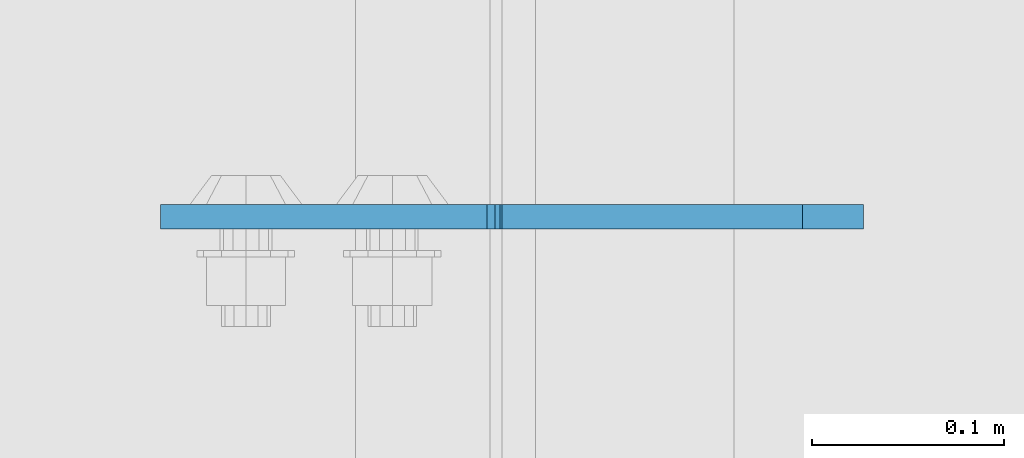
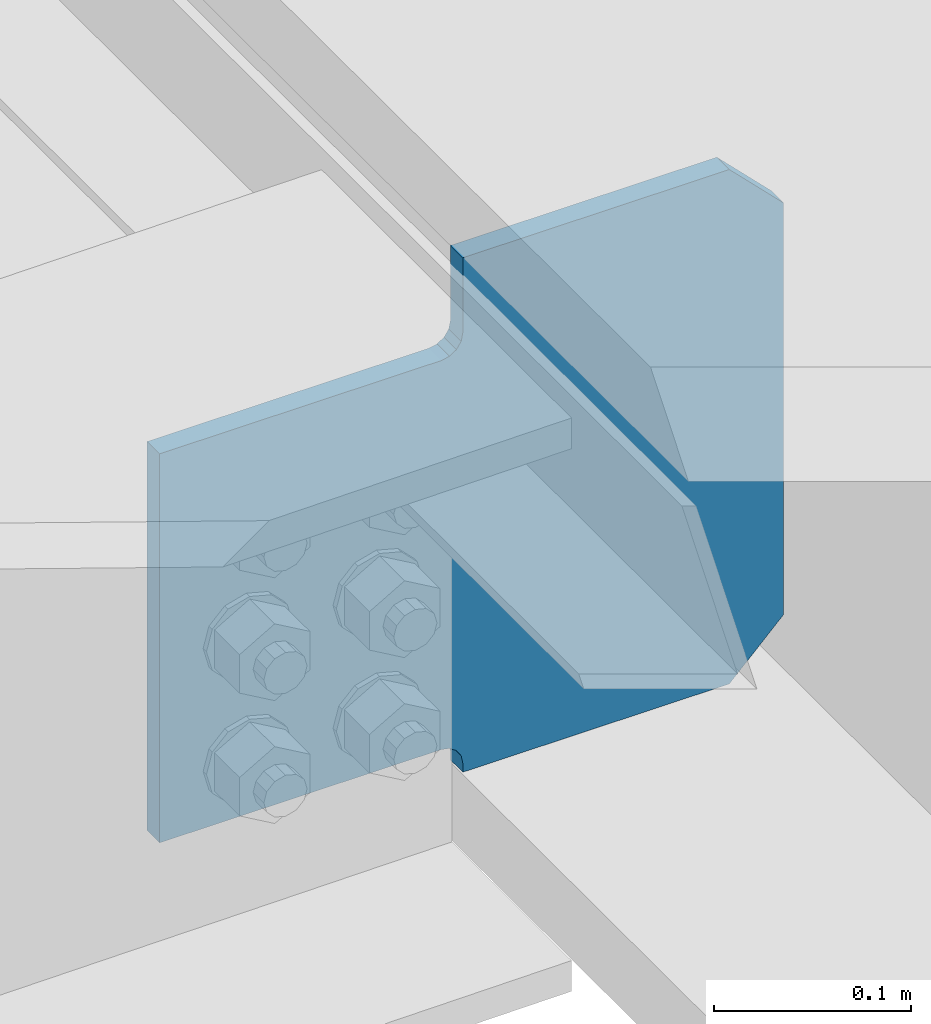
# One storey, part 3611 of 3843: 1 plate, 1 element without a shape of its own.
"""IFC2X3 building model written with IfcOpenShell, lengths in millimetres."""

from ifc_helpers import new_model, si_unit, frame, origin_with_axes, place, context, subcontext, project, spatial, faceted_brep, material, type_object, element, aggregate, save


model = new_model("IFC2X3")

# Units and contexts
model_context = context("Model", 3, precision=1e-05, world=origin_with_axes())
body_context = subcontext(model_context, "Body", "Model", "MODEL_VIEW")
ifc_project = project(units=[si_unit("LENGTHUNIT", "METRE", prefix="MILLI"), si_unit("AREAUNIT", "SQUARE_METRE"), si_unit("VOLUMEUNIT", "CUBIC_METRE"), si_unit("MASSUNIT", "GRAM", prefix="KILO"), si_unit("TIMEUNIT", "SECOND"), si_unit("PLANEANGLEUNIT", "RADIAN"), si_unit("SOLIDANGLEUNIT", "STERADIAN"), si_unit("THERMODYNAMICTEMPERATUREUNIT", "DEGREE_CELSIUS"), si_unit("LUMINOUSINTENSITYUNIT", "LUMEN")], contexts=[model_context])

# Site, building, storey
site_placement = place(None, origin_with_axes())
site = spatial("IfcSite", under=ifc_project, at=site_placement, CompositionType="ELEMENT")
building_placement = place(site_placement, origin_with_axes())
building = spatial("IfcBuilding", under=site, at=building_placement, Name="Undefined", CompositionType="ELEMENT")
storey_placement = place(building_placement, origin_with_axes())
storey = spatial("IfcBuildingStorey", under=building, at=storey_placement, Name="Undefined", CompositionType="ELEMENT", Elevation=0.0)

# Assembly, plate
assembly_placement = place(storey_placement, origin_with_axes())
assembly = element("IfcElementAssembly", 1, at=assembly_placement, inside=storey, Name="BEAM", AssemblyPlace="NOTDEFINED", PredefinedType="RIGID_FRAME")
ifc_material = material(Name="STEEL/A572-50")
plate_type = type_object("IfcPlateType", PredefinedType="NOTDEFINED")
plate_placement = place(assembly_placement, frame((85633.7187497331, 64497.545318173, 39422.8776364042), z_axis=(-0.707106781186548, 0.0, 0.707106781186548), x_axis=(-0.707106781186548, 0.0, -0.707106781186548)))
plate = element("IfcPlate", 2, at=plate_placement, type_object=plate_type, material=ifc_material, Name="PLATE", context=body_context, shape_type="Brep", body=[
    faceted_brep([(0.0, -6.3499999046162, 0.0), (-180.719415212428, -6.34999999999854, 180.719415212476), (-180.719415212428, 6.34999999999854, 180.719415212476), (7.27595761418343e-12, 6.3499999046162, 0.0), (-180.719415211977, -6.34999999999854, 225.620695818059), (-180.719415211977, 6.34999999999854, 225.620695818059), (-70.1500118726253, -6.34999999999854, 336.190099157397), (-70.1500118726253, 6.34999999999854, 336.190099157397), (-37.1738084875251, -6.34999999999854, 303.213895772296), (-37.1738084875251, 6.34999999999854, 303.213895772296), (-33.0536320193642, -6.34999999999854, 300.46088187183), (-33.0536320193642, 6.34999999999854, 300.46088187183), (-28.1935525013105, -6.34999999999854, 299.494151949264), (-28.1935525013105, 6.34999999999854, 299.494151949264), (-23.3334729832422, -6.34999999999854, 300.460881871881), (-23.3334729832422, 6.34999999999854, 300.460881871881), (-19.2132965150668, -6.34999999999854, 303.213895772387), (-19.2132965150668, 6.34999999999854, 303.213895772387), (97.5300333486812, -6.34999999999854, 419.957225636113), (97.5300333486812, 6.34999999999854, 419.957225636113), (268.154899648172, -6.34999999999854, 249.332359336597), (268.154899648172, 6.34999999999854, 249.332359336597), (151.411569784395, -6.34999999999854, 132.58902947286), (151.411569784395, 6.34999999999854, 132.58902947286), (148.658555883885, -6.34999999999854, 128.468853004684), (148.658555883885, 6.34999999999854, 128.468853004684), (147.691825961287, -6.34999999999854, 123.608773486631), (147.691825961287, 6.34999999999854, 123.608773486631), (148.658555883841, -6.34999999999854, 118.748693968566), (148.658555883841, 6.34999999999854, 118.748693968566), (151.411569784294, -6.34999999999854, 114.62851750042), (151.411569784294, 6.34999999999854, 114.62851750042), (155.470684068496, -6.35000000000582, 110.569403464237), (155.470684068496, 6.35000000000582, 110.569403464237), (44.9012806051323, -6.35000000000582, -1.45519152283669e-11), (44.9012806051323, 6.35000000000582, -1.45519152283669e-11)], [[[0, 1, 2, 3]], [[1, 4, 5, 2]], [[4, 6, 7, 5]], [[6, 8, 9, 7]], [[8, 10, 11, 9]], [[10, 12, 13, 11]], [[12, 14, 15, 13]], [[14, 16, 17, 15]], [[16, 18, 19, 17]], [[18, 20, 21, 19]], [[20, 22, 23, 21]], [[22, 24, 25, 23]], [[24, 26, 27, 25]], [[26, 28, 29, 27]], [[28, 30, 31, 29]], [[30, 32, 33, 31]], [[32, 34, 35, 33]], [[34, 0, 3, 35]], [[5, 7, 9, 11, 13, 15, 17, 19, 21, 23, 25, 27, 29, 31, 33, 35, 3, 2]], [[34, 32, 30, 28, 26, 24, 22, 20, 18, 16, 14, 12, 10, 8, 6, 4, 1, 0]]]),
])
aggregate(assembly, [plate])

save(model, "model.ifc")
